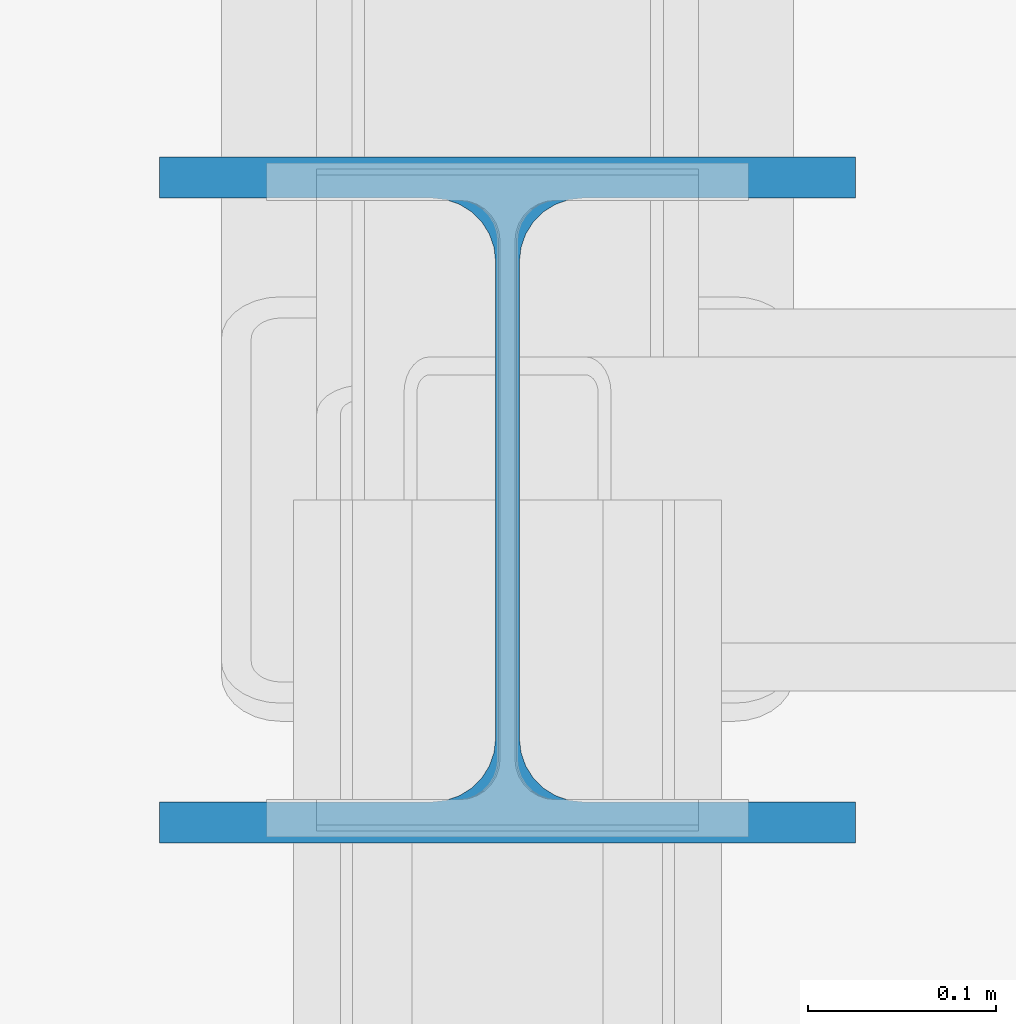
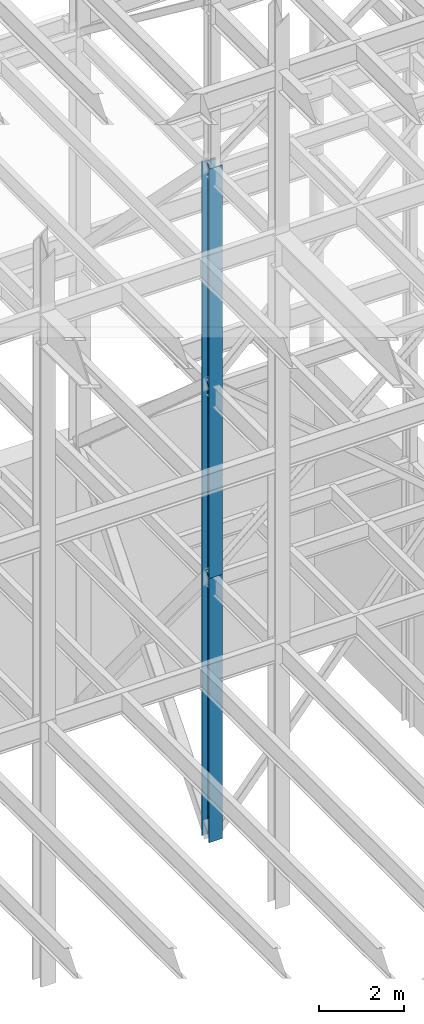
# One storey, part 115 of 150: 2 columns.
"""IFC2X3 building model written with IfcOpenShell, lengths in millimetres."""

import ifcopenshell
import ifcopenshell.guid

model = None  # the IFC model being written
_history = None  # IfcOwnerHistory: only IFC2X3 demands one
_inside = {}  # id of a spatial element -> (the spatial element, [elements in it])
_under = {}  # id of a project, library or spatial element -> (it, [spatial elements below it])
_declared = {}  # id of a project -> (the project, [libraries it declares])
_typed = {}  # id of a type object -> (the type object, [elements of that type])
_made_of = {}  # id of a material, layer set ... -> (it, [elements and type objects made of it])


def new_model(schema):
    """Start an empty IFC model of exactly this schema.

    Asked for "IFC4X3", IfcOpenShell would pick the latest addendum, in which some entities
    have other attributes; the version numbers below select the first issue.
    IFC2X3 requires an IfcOwnerHistory on every rooted entity: one is made here for all.
    """
    global model, _history
    if schema == "IFC4X3":
        model = ifcopenshell.file(schema_version=(4, 3, 0, 0))
    else:
        model = ifcopenshell.file(schema=schema)
    _inside.clear()
    _under.clear()
    _declared.clear()
    _typed.clear()
    _made_of.clear()
    _history = None
    if model.schema == "IFC2X3":
        org = make("IfcOrganization", Name="unknown")
        user = make(
            "IfcPersonAndOrganization",
            ThePerson=make("IfcPerson", FamilyName="unknown"),
            TheOrganization=org,
        )
        app = make(
            "IfcApplication",
            ApplicationDeveloper=org,
            Version="unknown",
            ApplicationFullName="unknown",
            ApplicationIdentifier="unknown",
        )
        _history = make(
            "IfcOwnerHistory",
            OwningUser=user,
            OwningApplication=app,
            ChangeAction="ADDED",
            CreationDate=0,
        )
    return model


def make(cls, **values):
    """One entity of the class cls with the attributes given. An attribute that is None is left unset."""
    return model.create_entity(
        cls, **{name: value for name, value in values.items() if value is not None}
    )


def rooted(cls, **values):
    """An entity with a GlobalId (a new one), such as an element, a storey or a relation."""
    return make(cls, GlobalId=ifcopenshell.guid.new(), OwnerHistory=_history, **values)


def si_unit(unit_type, name, prefix=None):
    """IfcSIUnit, for example si_unit("LENGTHUNIT", "METRE", prefix="MILLI")."""
    return make("IfcSIUnit", UnitType=unit_type, Prefix=prefix, Name=name)


def assignment(units):
    """IfcUnitAssignment: the units of a project."""
    return None if units is None else make("IfcUnitAssignment", Units=units)


def point(xyz):
    """IfcCartesianPoint."""
    return None if xyz is None else make("IfcCartesianPoint", Coordinates=xyz)


def direction(xyz):
    """IfcDirection."""
    return None if xyz is None else make("IfcDirection", DirectionRatios=xyz)


def frame(location, z_axis=None, x_axis=None):
    """IfcAxis2Placement3D, a coordinate frame: its origin and axes. An axis left out is left unset."""
    return make(
        "IfcAxis2Placement3D",
        Location=point(location),
        Axis=direction(z_axis),
        RefDirection=direction(x_axis),
    )


def frame_2d(location, x_axis=None):
    """IfcAxis2Placement2D, a coordinate frame in the plane: its origin and x axis."""
    return make(
        "IfcAxis2Placement2D", Location=point(location), RefDirection=direction(x_axis)
    )


def origin_with_axes():
    """The frame at (0, 0, 0) with the z axis (0, 0, 1) and the x axis (1, 0, 0) written out."""
    return frame((0.0, 0.0, 0.0), z_axis=(0.0, 0.0, 1.0), x_axis=(1.0, 0.0, 0.0))


def origin_2d_with_axis():
    """The frame at (0, 0) in the plane with the x axis (1, 0) written out."""
    return frame_2d((0.0, 0.0), x_axis=(1.0, 0.0))


def place(relative_to, where):
    """IfcLocalPlacement: puts the frame where relative to a parent placement (None: the world)."""
    return make(
        "IfcLocalPlacement", PlacementRelTo=relative_to, RelativePlacement=where
    )


def context(
    kind, dimensions, precision=None, world=None, true_north=None, identifier=None
):
    """IfcGeometricRepresentationContext, for example the 3D "Model" context."""
    return make(
        "IfcGeometricRepresentationContext",
        ContextIdentifier=identifier,
        ContextType=kind,
        CoordinateSpaceDimension=dimensions,
        Precision=precision,
        WorldCoordinateSystem=world,
        TrueNorth=true_north,
    )


def subcontext(parent, identifier, kind, view, scale=None):
    """IfcGeometricRepresentationSubContext, for example "Body" below "Model"."""
    return make(
        "IfcGeometricRepresentationSubContext",
        ContextIdentifier=identifier,
        ContextType=kind,
        ParentContext=parent,
        TargetScale=scale,
        TargetView=view,
    )


def project(units=None, contexts=None):
    """IfcProject with its units and contexts."""
    return rooted(
        "IfcProject",
        Name="project",
        RepresentationContexts=contexts,
        UnitsInContext=assignment(units),
    )


def spatial(cls, under=None, at=None, **own):
    """A site, building, storey or space (cls), placed at a placement, below another one or the project."""
    s = rooted(cls, ObjectPlacement=at, **own)
    if under is not None:
        _under.setdefault(under.id(), (under, []))[1].append(s)
    return s


def profile(cls, at=None, kind="AREA", **sizes):
    """A parametric profile (cls). Its sizes go by their IFC names, for example OverallWidth=200.0."""
    return make(cls, ProfileType=kind, Position=at, **sizes)


def i_section(**sizes):
    """IfcIShapeProfileDef."""
    return profile("IfcIShapeProfileDef", **sizes)


def extrude(swept, where, along, depth):
    """IfcExtrudedAreaSolid: the profile swept, set in the frame where, extruded along a direction by depth."""
    return make(
        "IfcExtrudedAreaSolid",
        SweptArea=swept,
        Position=where,
        ExtrudedDirection=direction(along),
        Depth=depth,
    )


def shape(context_of_items, identifier, shape_type, items):
    """IfcShapeRepresentation: the items that make up one representation, for example the "Body"."""
    return make(
        "IfcShapeRepresentation",
        ContextOfItems=context_of_items,
        RepresentationIdentifier=identifier,
        RepresentationType=shape_type,
        Items=items,
    )


def material(Name=None, Category=None):
    """IfcMaterial."""
    return make("IfcMaterial", Name=Name, Category=Category)


def made_of(thing, what):
    """Note that an element or type object is made of a material, layer set ...; save() writes the relation."""
    if what is not None:
        _made_of.setdefault(what.id(), (what, []))[1].append(thing)
    return thing


def type_object(cls, material=None, **own):
    """A type object (cls), such as IfcWallType, which elements share."""
    return made_of(rooted(cls, **own), material)


def element(
    cls,
    number,
    at=None,
    inside=None,
    cuts=None,
    type_object=None,
    material=None,
    context=None,
    identifier="Body",
    shape_type=None,
    held_by="IfcProductDefinitionShape",
    body=None,
    shapes=None,
    **own,
):
    """One element of the class cls, such as IfcWall. Its Tag is "e" and its number.

    at: its placement. inside: the storey or other place that contains it. cuts: it is an
    opening in that element (IfcRelVoidsElement). A single representation is given by context,
    identifier, shape_type and body (its items); several are given by shapes. held_by: the class
    of the entity that holds the representations. save() writes the other relations.
    """
    e = rooted(cls, Tag="e%d" % number, ObjectPlacement=at, **own)
    if body is not None:
        shapes = [shape(context, identifier, shape_type, body)]
    if shapes is not None:
        e.Representation = make(held_by, Representations=shapes)
    if inside is not None:
        _inside.setdefault(inside.id(), (inside, []))[1].append(e)
    if cuts is not None:
        rooted(
            "IfcRelVoidsElement", RelatingBuildingElement=cuts, RelatedOpeningElement=e
        )
    if type_object is not None:
        _typed.setdefault(type_object.id(), (type_object, []))[1].append(e)
    return made_of(e, material)


def aggregate(whole, parts):
    """IfcRelAggregates: a whole, such as a stair, and the parts it consists of."""
    return rooted("IfcRelAggregates", RelatingObject=whole, RelatedObjects=parts)


def save(model, path):
    """Write the relations noted so far, then the file.

    IfcRelAggregates (storeys below a building ...), IfcRelContainedInSpatialStructure (elements
    in a storey), IfcRelDefinesByType, IfcRelAssociatesMaterial and IfcRelDeclares: one each for
    every whole, place, type object, material and project.
    """
    for whole, parts in _under.values():
        aggregate(whole, parts)
    for where, things in _inside.values():
        rooted(
            "IfcRelContainedInSpatialStructure",
            RelatedElements=things,
            RelatingStructure=where,
        )
    for kind, things in _typed.values():
        rooted("IfcRelDefinesByType", RelatedObjects=things, RelatingType=kind)
    for what, things in _made_of.values():
        rooted("IfcRelAssociatesMaterial", RelatedObjects=things, RelatingMaterial=what)
    for by, libraries in _declared.values():
        rooted("IfcRelDeclares", RelatingContext=by, RelatedDefinitions=libraries)
    model.write(path)


model = new_model("IFC2X3")

# Units and contexts
model_context = context("Model", 3, precision=1e-05, world=origin_with_axes())
body_context = subcontext(model_context, "Body", "Model", "MODEL_VIEW")
ifc_project = project(units=[si_unit("LENGTHUNIT", "METRE", prefix="MILLI"), si_unit("AREAUNIT", "SQUARE_METRE"), si_unit("VOLUMEUNIT", "CUBIC_METRE"), si_unit("MASSUNIT", "GRAM", prefix="KILO"), si_unit("TIMEUNIT", "SECOND"), si_unit("PLANEANGLEUNIT", "RADIAN"), si_unit("SOLIDANGLEUNIT", "STERADIAN"), si_unit("THERMODYNAMICTEMPERATUREUNIT", "DEGREE_CELSIUS"), si_unit("LUMINOUSINTENSITYUNIT", "LUMEN")], contexts=[model_context])

# Site, building, storey
site_placement = place(None, origin_with_axes())
site = spatial("IfcSite", under=ifc_project, at=site_placement, CompositionType="ELEMENT")
building_placement = place(site_placement, origin_with_axes())
building = spatial("IfcBuilding", under=site, at=building_placement, Name="Undefined", CompositionType="ELEMENT")
storey_placement = place(building_placement, origin_with_axes())
storey = spatial("IfcBuildingStorey", under=building, at=storey_placement, Name="Undefined", CompositionType="ELEMENT", Elevation=0.0)

# Columns
ifc_material = material(Name="STEEL/A992")
column_type = type_object("IfcColumnType", Name="W14X109", PredefinedType="NOTDEFINED")
column_1_placement = place(storey_placement, frame((82194.4, 25628.6, 23774.4), z_axis=(0.0, 0.0, 1.0), x_axis=(1.0, 0.0, 0.0)))
element("IfcColumn", 1, at=column_1_placement, inside=storey, type_object=column_type, material=ifc_material, Name="COLUMN", ObjectType="W14X109", context=body_context, shape_type="SweptSolid", body=[
    extrude(i_section(OverallWidth=370.84, OverallDepth=365.125, WebThickness=12.6999, FlangeThickness=21.844, FilletRadius=33.7184, at=origin_2d_with_axis()), frame((0.0, 0.0, 11811.0), z_axis=(0.0, 0.0, -1.0), x_axis=(-1.0, 0.0, 0.0)), (0.0, 0.0, 1.0), 11811.0),
])
column_2_placement = place(storey_placement, frame((82194.4, 25628.6, 16154.4), z_axis=(0.0, 0.0, 1.0), x_axis=(1.0, 0.0, 0.0)))
element("IfcColumn", 2, at=column_2_placement, inside=storey, type_object=column_type, material=ifc_material, Name="COLUMN", ObjectType="W14X109", context=body_context, shape_type="SweptSolid", body=[
    extrude(i_section(OverallWidth=370.84, OverallDepth=365.125, WebThickness=12.6999, FlangeThickness=21.844, FilletRadius=33.7184, at=origin_2d_with_axis()), frame((0.0, 0.0, 7620.0), z_axis=(0.0, 0.0, -1.0), x_axis=(-1.0, 0.0, 0.0)), (0.0, 0.0, 1.0), 7620.0),
])

save(model, "model.ifc")
